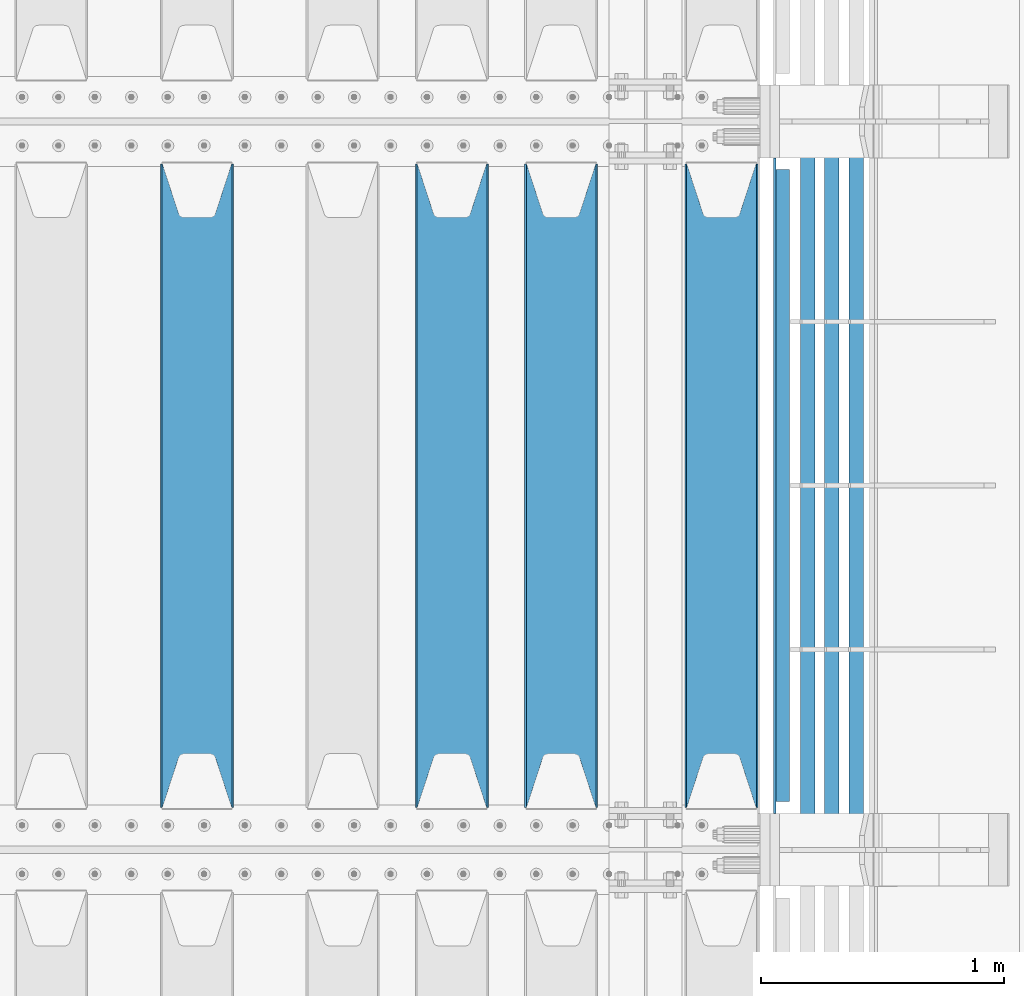
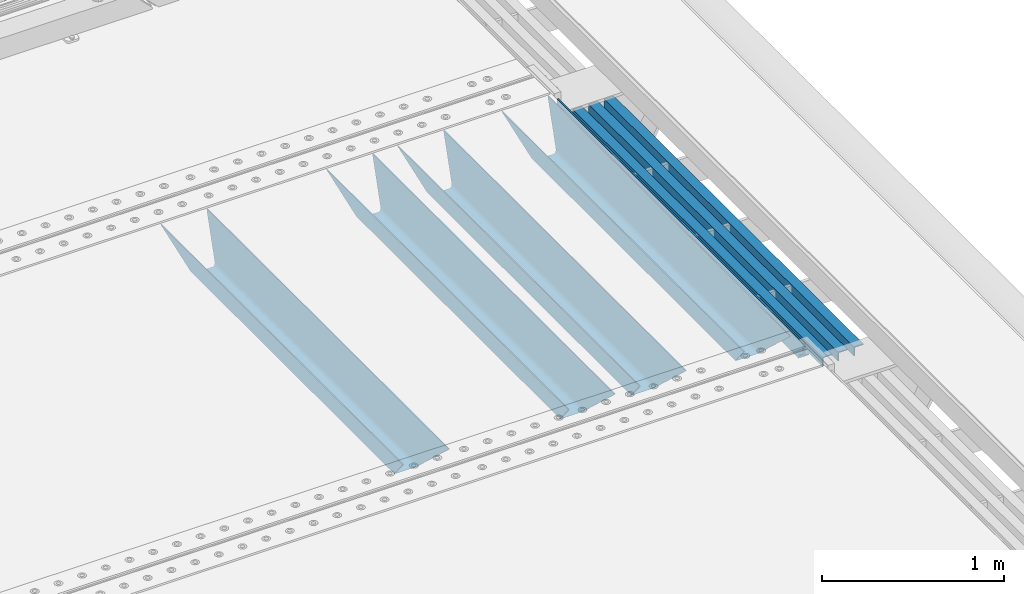
# One storey, part 143 of 270: 8 beams.
"""IFC2X3 building model written with IfcOpenShell, lengths in millimetres."""

import ifcopenshell
import ifcopenshell.guid

model = None  # the IFC model being written
_history = None  # IfcOwnerHistory: only IFC2X3 demands one
_inside = {}  # id of a spatial element -> (the spatial element, [elements in it])
_under = {}  # id of a project, library or spatial element -> (it, [spatial elements below it])
_declared = {}  # id of a project -> (the project, [libraries it declares])
_typed = {}  # id of a type object -> (the type object, [elements of that type])
_made_of = {}  # id of a material, layer set ... -> (it, [elements and type objects made of it])


def new_model(schema):
    """Start an empty IFC model of exactly this schema.

    Asked for "IFC4X3", IfcOpenShell would pick the latest addendum, in which some entities
    have other attributes; the version numbers below select the first issue.
    IFC2X3 requires an IfcOwnerHistory on every rooted entity: one is made here for all.
    """
    global model, _history
    if schema == "IFC4X3":
        model = ifcopenshell.file(schema_version=(4, 3, 0, 0))
    else:
        model = ifcopenshell.file(schema=schema)
    _inside.clear()
    _under.clear()
    _declared.clear()
    _typed.clear()
    _made_of.clear()
    _history = None
    if model.schema == "IFC2X3":
        org = make("IfcOrganization", Name="unknown")
        user = make(
            "IfcPersonAndOrganization",
            ThePerson=make("IfcPerson", FamilyName="unknown"),
            TheOrganization=org,
        )
        app = make(
            "IfcApplication",
            ApplicationDeveloper=org,
            Version="unknown",
            ApplicationFullName="unknown",
            ApplicationIdentifier="unknown",
        )
        _history = make(
            "IfcOwnerHistory",
            OwningUser=user,
            OwningApplication=app,
            ChangeAction="ADDED",
            CreationDate=0,
        )
    return model


def make(cls, **values):
    """One entity of the class cls with the attributes given. An attribute that is None is left unset."""
    return model.create_entity(
        cls, **{name: value for name, value in values.items() if value is not None}
    )


def rooted(cls, **values):
    """An entity with a GlobalId (a new one), such as an element, a storey or a relation."""
    return make(cls, GlobalId=ifcopenshell.guid.new(), OwnerHistory=_history, **values)


def si_unit(unit_type, name, prefix=None):
    """IfcSIUnit, for example si_unit("LENGTHUNIT", "METRE", prefix="MILLI")."""
    return make("IfcSIUnit", UnitType=unit_type, Prefix=prefix, Name=name)


def assignment(units):
    """IfcUnitAssignment: the units of a project."""
    return None if units is None else make("IfcUnitAssignment", Units=units)


def point(xyz):
    """IfcCartesianPoint."""
    return None if xyz is None else make("IfcCartesianPoint", Coordinates=xyz)


def direction(xyz):
    """IfcDirection."""
    return None if xyz is None else make("IfcDirection", DirectionRatios=xyz)


def frame(location, z_axis=None, x_axis=None):
    """IfcAxis2Placement3D, a coordinate frame: its origin and axes. An axis left out is left unset."""
    return make(
        "IfcAxis2Placement3D",
        Location=point(location),
        Axis=direction(z_axis),
        RefDirection=direction(x_axis),
    )


def origin_with_axes():
    """The frame at (0, 0, 0) with the z axis (0, 0, 1) and the x axis (1, 0, 0) written out."""
    return frame((0.0, 0.0, 0.0), z_axis=(0.0, 0.0, 1.0), x_axis=(1.0, 0.0, 0.0))


def place(relative_to, where):
    """IfcLocalPlacement: puts the frame where relative to a parent placement (None: the world)."""
    return make(
        "IfcLocalPlacement", PlacementRelTo=relative_to, RelativePlacement=where
    )


def context(
    kind, dimensions, precision=None, world=None, true_north=None, identifier=None
):
    """IfcGeometricRepresentationContext, for example the 3D "Model" context."""
    return make(
        "IfcGeometricRepresentationContext",
        ContextIdentifier=identifier,
        ContextType=kind,
        CoordinateSpaceDimension=dimensions,
        Precision=precision,
        WorldCoordinateSystem=world,
        TrueNorth=true_north,
    )


def subcontext(parent, identifier, kind, view, scale=None):
    """IfcGeometricRepresentationSubContext, for example "Body" below "Model"."""
    return make(
        "IfcGeometricRepresentationSubContext",
        ContextIdentifier=identifier,
        ContextType=kind,
        ParentContext=parent,
        TargetScale=scale,
        TargetView=view,
    )


def project(units=None, contexts=None):
    """IfcProject with its units and contexts."""
    return rooted(
        "IfcProject",
        Name="project",
        RepresentationContexts=contexts,
        UnitsInContext=assignment(units),
    )


def spatial(cls, under=None, at=None, **own):
    """A site, building, storey or space (cls), placed at a placement, below another one or the project."""
    s = rooted(cls, ObjectPlacement=at, **own)
    if under is not None:
        _under.setdefault(under.id(), (under, []))[1].append(s)
    return s


def faces_of(points, faces, orient=None, outer=None):
    """IfcFace entities. A face is a list of loops; a loop is a list of indices into points, from 0.

    orient and outer hold one flag for each loop. By default every Orientation is true, the
    first loop of a face is its IfcFaceOuterBound and the others are IfcFaceBound.
    """
    made = []
    for i, loops in enumerate(faces):
        bounds = []
        for j, loop in enumerate(loops):
            is_outer = j == 0 if outer is None else outer[i][j]
            bounds.append(
                make(
                    "IfcFaceOuterBound" if is_outer else "IfcFaceBound",
                    Bound=make("IfcPolyLoop", Polygon=[points[k] for k in loop]),
                    Orientation=True if orient is None else orient[i][j],
                )
            )
        made.append(make("IfcFace", Bounds=bounds))
    return made


def faceted_brep(points, faces, orient=None, outer=None, voids=None):
    """IfcFacetedBrep: a solid bounded by flat faces; with voids (closed shells), ...WithVoids."""
    shared = [point(p) for p in points]
    hull = make("IfcClosedShell", CfsFaces=faces_of(shared, faces, orient, outer))
    if voids is None:
        return make("IfcFacetedBrep", Outer=hull)
    return make(
        "IfcFacetedBrepWithVoids",
        Outer=hull,
        Voids=[
            make(cls, CfsFaces=faces_of(shared, fs, o, b)) for cls, fs, o, b in voids
        ],
    )


def shape(context_of_items, identifier, shape_type, items):
    """IfcShapeRepresentation: the items that make up one representation, for example the "Body"."""
    return make(
        "IfcShapeRepresentation",
        ContextOfItems=context_of_items,
        RepresentationIdentifier=identifier,
        RepresentationType=shape_type,
        Items=items,
    )


def material(Name=None, Category=None):
    """IfcMaterial."""
    return make("IfcMaterial", Name=Name, Category=Category)


def made_of(thing, what):
    """Note that an element or type object is made of a material, layer set ...; save() writes the relation."""
    if what is not None:
        _made_of.setdefault(what.id(), (what, []))[1].append(thing)
    return thing


def type_object(cls, material=None, **own):
    """A type object (cls), such as IfcWallType, which elements share."""
    return made_of(rooted(cls, **own), material)


def element(
    cls,
    number,
    at=None,
    inside=None,
    cuts=None,
    type_object=None,
    material=None,
    context=None,
    identifier="Body",
    shape_type=None,
    held_by="IfcProductDefinitionShape",
    body=None,
    shapes=None,
    **own,
):
    """One element of the class cls, such as IfcWall. Its Tag is "e" and its number.

    at: its placement. inside: the storey or other place that contains it. cuts: it is an
    opening in that element (IfcRelVoidsElement). A single representation is given by context,
    identifier, shape_type and body (its items); several are given by shapes. held_by: the class
    of the entity that holds the representations. save() writes the other relations.
    """
    e = rooted(cls, Tag="e%d" % number, ObjectPlacement=at, **own)
    if body is not None:
        shapes = [shape(context, identifier, shape_type, body)]
    if shapes is not None:
        e.Representation = make(held_by, Representations=shapes)
    if inside is not None:
        _inside.setdefault(inside.id(), (inside, []))[1].append(e)
    if cuts is not None:
        rooted(
            "IfcRelVoidsElement", RelatingBuildingElement=cuts, RelatedOpeningElement=e
        )
    if type_object is not None:
        _typed.setdefault(type_object.id(), (type_object, []))[1].append(e)
    return made_of(e, material)


def aggregate(whole, parts):
    """IfcRelAggregates: a whole, such as a stair, and the parts it consists of."""
    return rooted("IfcRelAggregates", RelatingObject=whole, RelatedObjects=parts)


def save(model, path):
    """Write the relations noted so far, then the file.

    IfcRelAggregates (storeys below a building ...), IfcRelContainedInSpatialStructure (elements
    in a storey), IfcRelDefinesByType, IfcRelAssociatesMaterial and IfcRelDeclares: one each for
    every whole, place, type object, material and project.
    """
    for whole, parts in _under.values():
        aggregate(whole, parts)
    for where, things in _inside.values():
        rooted(
            "IfcRelContainedInSpatialStructure",
            RelatedElements=things,
            RelatingStructure=where,
        )
    for kind, things in _typed.values():
        rooted("IfcRelDefinesByType", RelatedObjects=things, RelatingType=kind)
    for what, things in _made_of.values():
        rooted("IfcRelAssociatesMaterial", RelatedObjects=things, RelatingMaterial=what)
    for by, libraries in _declared.values():
        rooted("IfcRelDeclares", RelatingContext=by, RelatedDefinitions=libraries)
    model.write(path)


model = new_model("IFC2X3")

# Units and contexts
model_context = context("Model", 3, precision=1e-05, world=origin_with_axes())
body_context = subcontext(model_context, "Body", "Model", "MODEL_VIEW")
ifc_project = project(units=[si_unit("LENGTHUNIT", "METRE", prefix="MILLI"), si_unit("AREAUNIT", "SQUARE_METRE"), si_unit("VOLUMEUNIT", "CUBIC_METRE"), si_unit("MASSUNIT", "GRAM", prefix="KILO"), si_unit("TIMEUNIT", "SECOND"), si_unit("PLANEANGLEUNIT", "RADIAN"), si_unit("SOLIDANGLEUNIT", "STERADIAN"), si_unit("THERMODYNAMICTEMPERATUREUNIT", "DEGREE_CELSIUS"), si_unit("LUMINOUSINTENSITYUNIT", "LUMEN")], contexts=[model_context])

# Site, building, storey
site_placement = place(None, origin_with_axes())
site = spatial("IfcSite", under=ifc_project, at=site_placement, CompositionType="ELEMENT")
building_placement = place(site_placement, origin_with_axes())
building = spatial("IfcBuilding", under=site, at=building_placement, Name="Standard", CompositionType="ELEMENT")
storey_placement = place(building_placement, origin_with_axes())
storey = spatial("IfcBuildingStorey", under=building, at=storey_placement, Name="Undefined", CompositionType="ELEMENT", Elevation=0.0)

# Beams
ifc_material_1 = material(Name="STEEL/S355N")
beam_type_1 = type_object("IfcBeamType", PredefinedType="NOTDEFINED")
beam_1_placement = place(storey_placement, frame((20230.0, -20825.0, -115.0), z_axis=(0.0, 0.0, 1.0), x_axis=(0.0, 1.0, 0.0)))
element("IfcBeam", 1, at=beam_1_placement, inside=storey, type_object=beam_type_1, material=ifc_material_1, context=body_context, shape_type="Brep", body=[
    faceted_brep([(0.0, 150.0, 115.0), (0.0, 143.689999999999, 115.0), (2650.00000000297, 143.689999999999, 115.0), (2650.00000000297, 150.0, 115.0), (2650.00000000297, 142.059565218398, 110.000000003096), (2650.00000000297, 148.3695652184, 110.000000003096), (2441.90079219209, -80.1103600731112, -98.0992078077845), (2437.7588105432, -77.5672621345584, -102.241189456673), (2434.06523489747, -74.4080125315522, -105.934765102404), (2430.9108609509, -70.710272125576, -109.089139048974), (2428.37322971128, -66.5649389910068, -111.626770288588), (2426.51472138055, -62.0739139532889, -113.485278619323), (2425.38102192092, -57.3475956567672, -114.618978078955), (2424.99999999987, -52.5021667386536, -115.0), (2424.99999999987, 52.5021667386536, -115.0), (2425.38102192092, 57.3475956567672, -114.618978078955), (2426.51472138055, 62.0739139532889, -113.485278619323), (2428.37322971128, 66.5649389910068, -111.626770288588), (2430.9108609509, 70.710272125576, -109.089139048974), (2434.06523489747, 74.4080125315522, -105.934765102404), (2437.7588105432, 77.5672621345584, -102.241189456673), (2441.90079219209, 80.1103600731112, -98.0992078077846), (2446.38936140511, 81.9747917625791, -93.6106385947584), (2448.2494850041, 76.2713538057251, -91.7505149957729), (2444.62967112263, 74.76777986261, -95.3703288772456), (2441.28936334126, 72.7168944282894, -98.710636658607), (2438.31067330439, 70.1691124903846, -101.689326695487), (2435.76682334747, 67.1870637758839, -104.233176652398), (2433.72034654133, 63.8440531834895, -106.279653458539), (2432.22154950042, 60.222258798236, -107.778450499454), (2431.30727574265, 56.4107117849089, -108.692724257221), (2430.99999999987, 52.5031078186876, -109.0), (2430.99999999987, -52.5031078186876, -109.0), (2431.30727574265, -56.4107117849089, -108.692724257221), (2432.22154950042, -60.222258798236, -107.778450499454), (2433.72034654133, -63.8440531834895, -106.279653458539), (2435.76682334747, -67.1870637758839, -104.233176652398), (2438.31067330438, -70.1691124903846, -101.689326695487), (2441.28936334126, -72.7168944282894, -98.7106366586071), (2444.62967112263, -74.76777986261, -95.3703288772457), (2448.2494850041, -76.2713538057251, -91.7505149957729), (2650.00000000297, -142.059565218398, 110.000000003096), (2650.00000000297, -148.3695652184, 110.000000003096), (2446.38936140511, -81.9747917625791, -93.6106385947584), (2650.00000000297, -143.689999999999, 115.0), (2650.00000000297, -150.0, 115.0), (0.0, -143.689999999999, 115.0), (0.0, -150.0, 115.0), (0.0, -148.369565218261, 110.000000002672), (203.610638597431, -81.9747917625791, -93.6106385947584), (208.099207810457, -80.1103600731112, -98.0992078077845), (212.241189459342, -77.5672621345584, -102.241189456673), (215.934765105078, -74.4080125315522, -105.934765102404), (219.089139051644, -70.710272125576, -109.089139048974), (221.626770291259, -66.5649389910068, -111.626770288588), (223.485278621993, -62.0739139532889, -113.485278619323), (224.618978081628, -57.3475956567672, -114.618978078955), (225.00000000267, -52.5021667386536, -115.0), (225.00000000267, 52.5021667386536, -115.0), (224.618978081628, 57.3475956567672, -114.618978078955), (223.485278621993, 62.0739139532889, -113.485278619323), (221.626770291259, 66.5649389910068, -111.626770288588), (219.089139051644, 70.710272125576, -109.089139048974), (215.934765105078, 74.4080125315522, -105.934765102404), (212.241189459342, 77.5672621345584, -102.241189456673), (208.099207810457, 80.1103600731112, -98.0992078077846), (203.610638597431, 81.9747917625791, -93.6106385947584), (0.0, 148.369565218261, 110.000000002672), (0.0, 142.05956521826, 110.000000002672), (201.750514998446, 76.2713538057251, -91.7505149957729), (205.370328879915, 74.76777986261, -95.3703288772456), (208.710636661279, 72.7168944282894, -98.710636658607), (211.689326698157, 70.1691124903846, -101.689326695487), (214.233176655071, 67.1870637758839, -104.233176652398), (216.27965346121, 63.8440531834895, -106.279653458539), (217.778450502126, 60.222258798236, -107.778450499454), (218.692724259894, 56.4107117849089, -108.692724257221), (219.00000000267, 52.5031078186876, -109.0), (219.00000000267, -52.5031078186876, -109.0), (218.692724259894, -56.4107117849089, -108.692724257221), (217.778450502123, -60.222258798236, -107.778450499454), (216.27965346121, -63.8440531834895, -106.279653458539), (214.233176655071, -67.1870637758839, -104.233176652398), (211.689326698157, -70.1691124903846, -101.689326695487), (208.710636661279, -72.7168944282894, -98.7106366586071), (205.370328879915, -74.76777986261, -95.3703288772457), (201.750514998446, -76.2713538057251, -91.7505149957729), (0.0, -142.05956521826, 110.000000002672)], [[[0, 1, 2, 3]], [[3, 2, 4, 5]], [[6, 7, 8, 9, 10, 11, 12, 13, 14, 15, 16, 17, 18, 19, 20, 21, 22, 5, 4, 23, 24, 25, 26, 27, 28, 29, 30, 31, 32, 33, 34, 35, 36, 37, 38, 39, 40, 41, 42, 43]], [[44, 45, 42, 41]], [[46, 47, 45, 44]], [[43, 42, 45, 47, 48, 49]], [[6, 43, 49, 50]], [[7, 6, 50, 51]], [[8, 7, 51, 52]], [[9, 8, 52, 53]], [[10, 9, 53, 54]], [[11, 10, 54, 55]], [[12, 11, 55, 56]], [[13, 12, 56, 57]], [[14, 13, 57, 58]], [[15, 14, 58, 59]], [[16, 15, 59, 60]], [[17, 16, 60, 61]], [[18, 17, 61, 62]], [[19, 18, 62, 63]], [[20, 19, 63, 64]], [[21, 20, 64, 65]], [[22, 21, 65, 66]], [[0, 3, 5, 22, 66, 67]], [[1, 0, 67, 68]], [[23, 4, 2, 1, 68, 69]], [[24, 23, 69, 70]], [[25, 24, 70, 71]], [[26, 25, 71, 72]], [[27, 26, 72, 73]], [[28, 27, 73, 74]], [[29, 28, 74, 75]], [[30, 29, 75, 76]], [[31, 30, 76, 77]], [[32, 31, 77, 78]], [[33, 32, 78, 79]], [[34, 33, 79, 80]], [[35, 34, 80, 81]], [[36, 35, 81, 82]], [[37, 36, 82, 83]], [[38, 37, 83, 84]], [[39, 38, 84, 85]], [[40, 39, 85, 86]], [[46, 44, 41, 40, 86, 87]], [[47, 46, 87, 48]], [[86, 85, 84, 83, 82, 81, 80, 79, 78, 77, 76, 75, 74, 73, 72, 71, 70, 69, 68, 67, 66, 65, 64, 63, 62, 61, 60, 59, 58, 57, 56, 55, 54, 53, 52, 51, 50, 49, 48, 87]]]),
])
beam_2_placement = place(storey_placement, frame((19570.0, -20825.0, -115.0), z_axis=(0.0, 0.0, 1.0), x_axis=(0.0, 1.0, 0.0)))
element("IfcBeam", 2, at=beam_2_placement, inside=storey, type_object=beam_type_1, material=ifc_material_1, context=body_context, shape_type="Brep", body=[
    faceted_brep([(0.0, 150.0, 115.0), (0.0, 143.689999999999, 115.0), (2650.00000000297, 143.689999999999, 115.0), (2650.00000000297, 150.0, 115.0), (2650.00000000297, 142.059565218398, 110.000000003096), (2650.00000000297, 148.3695652184, 110.000000003096), (2441.90079219209, -80.1103600731112, -98.0992078077845), (2437.7588105432, -77.5672621345584, -102.241189456673), (2434.06523489747, -74.4080125315522, -105.934765102404), (2430.9108609509, -70.710272125576, -109.089139048974), (2428.37322971128, -66.5649389910068, -111.626770288588), (2426.51472138055, -62.0739139532889, -113.485278619323), (2425.38102192092, -57.3475956567672, -114.618978078955), (2424.99999999987, -52.5021667386536, -115.0), (2424.99999999987, 52.5021667386536, -115.0), (2425.38102192092, 57.3475956567672, -114.618978078955), (2426.51472138055, 62.0739139532889, -113.485278619323), (2428.37322971128, 66.5649389910068, -111.626770288588), (2430.9108609509, 70.710272125576, -109.089139048974), (2434.06523489747, 74.4080125315522, -105.934765102404), (2437.7588105432, 77.5672621345584, -102.241189456673), (2441.90079219209, 80.1103600731112, -98.0992078077846), (2446.38936140511, 81.9747917625791, -93.6106385947584), (2448.2494850041, 76.2713538057251, -91.7505149957729), (2444.62967112263, 74.76777986261, -95.3703288772456), (2441.28936334126, 72.7168944282894, -98.710636658607), (2438.31067330439, 70.1691124903846, -101.689326695487), (2435.76682334747, 67.1870637758839, -104.233176652398), (2433.72034654133, 63.8440531834895, -106.279653458539), (2432.22154950042, 60.222258798236, -107.778450499454), (2431.30727574265, 56.4107117849089, -108.692724257221), (2430.99999999987, 52.5031078186876, -109.0), (2430.99999999987, -52.5031078186876, -109.0), (2431.30727574265, -56.4107117849089, -108.692724257221), (2432.22154950042, -60.222258798236, -107.778450499454), (2433.72034654133, -63.8440531834895, -106.279653458539), (2435.76682334747, -67.1870637758839, -104.233176652398), (2438.31067330438, -70.1691124903846, -101.689326695487), (2441.28936334126, -72.7168944282894, -98.7106366586071), (2444.62967112263, -74.76777986261, -95.3703288772457), (2448.2494850041, -76.2713538057251, -91.7505149957729), (2650.00000000297, -142.059565218398, 110.000000003096), (2650.00000000297, -148.3695652184, 110.000000003096), (2446.38936140511, -81.9747917625791, -93.6106385947584), (2650.00000000297, -143.689999999999, 115.0), (2650.00000000297, -150.0, 115.0), (0.0, -143.689999999999, 115.0), (0.0, -150.0, 115.0), (0.0, -148.369565218261, 110.000000002672), (203.610638597431, -81.9747917625791, -93.6106385947584), (208.099207810457, -80.1103600731112, -98.0992078077845), (212.241189459342, -77.5672621345584, -102.241189456673), (215.934765105078, -74.4080125315522, -105.934765102404), (219.089139051644, -70.710272125576, -109.089139048974), (221.626770291259, -66.5649389910068, -111.626770288588), (223.485278621993, -62.0739139532889, -113.485278619323), (224.618978081628, -57.3475956567672, -114.618978078955), (225.00000000267, -52.5021667386536, -115.0), (225.00000000267, 52.5021667386536, -115.0), (224.618978081628, 57.3475956567672, -114.618978078955), (223.485278621993, 62.0739139532889, -113.485278619323), (221.626770291259, 66.5649389910068, -111.626770288588), (219.089139051644, 70.710272125576, -109.089139048974), (215.934765105078, 74.4080125315522, -105.934765102404), (212.241189459342, 77.5672621345584, -102.241189456673), (208.099207810457, 80.1103600731112, -98.0992078077846), (203.610638597431, 81.9747917625791, -93.6106385947584), (0.0, 148.369565218261, 110.000000002672), (0.0, 142.05956521826, 110.000000002672), (201.750514998446, 76.2713538057251, -91.7505149957729), (205.370328879915, 74.76777986261, -95.3703288772456), (208.710636661279, 72.7168944282894, -98.710636658607), (211.689326698157, 70.1691124903846, -101.689326695487), (214.233176655071, 67.1870637758839, -104.233176652398), (216.27965346121, 63.8440531834895, -106.279653458539), (217.778450502126, 60.222258798236, -107.778450499454), (218.692724259894, 56.4107117849089, -108.692724257221), (219.00000000267, 52.5031078186876, -109.0), (219.00000000267, -52.5031078186876, -109.0), (218.692724259894, -56.4107117849089, -108.692724257221), (217.778450502123, -60.222258798236, -107.778450499454), (216.27965346121, -63.8440531834895, -106.279653458539), (214.233176655071, -67.1870637758839, -104.233176652398), (211.689326698157, -70.1691124903846, -101.689326695487), (208.710636661279, -72.7168944282894, -98.7106366586071), (205.370328879915, -74.76777986261, -95.3703288772457), (201.750514998446, -76.2713538057251, -91.7505149957729), (0.0, -142.05956521826, 110.000000002672)], [[[0, 1, 2, 3]], [[3, 2, 4, 5]], [[6, 7, 8, 9, 10, 11, 12, 13, 14, 15, 16, 17, 18, 19, 20, 21, 22, 5, 4, 23, 24, 25, 26, 27, 28, 29, 30, 31, 32, 33, 34, 35, 36, 37, 38, 39, 40, 41, 42, 43]], [[44, 45, 42, 41]], [[46, 47, 45, 44]], [[43, 42, 45, 47, 48, 49]], [[6, 43, 49, 50]], [[7, 6, 50, 51]], [[8, 7, 51, 52]], [[9, 8, 52, 53]], [[10, 9, 53, 54]], [[11, 10, 54, 55]], [[12, 11, 55, 56]], [[13, 12, 56, 57]], [[14, 13, 57, 58]], [[15, 14, 58, 59]], [[16, 15, 59, 60]], [[17, 16, 60, 61]], [[18, 17, 61, 62]], [[19, 18, 62, 63]], [[20, 19, 63, 64]], [[21, 20, 64, 65]], [[22, 21, 65, 66]], [[0, 3, 5, 22, 66, 67]], [[1, 0, 67, 68]], [[23, 4, 2, 1, 68, 69]], [[24, 23, 69, 70]], [[25, 24, 70, 71]], [[26, 25, 71, 72]], [[27, 26, 72, 73]], [[28, 27, 73, 74]], [[29, 28, 74, 75]], [[30, 29, 75, 76]], [[31, 30, 76, 77]], [[32, 31, 77, 78]], [[33, 32, 78, 79]], [[34, 33, 79, 80]], [[35, 34, 80, 81]], [[36, 35, 81, 82]], [[37, 36, 82, 83]], [[38, 37, 83, 84]], [[39, 38, 84, 85]], [[40, 39, 85, 86]], [[46, 44, 41, 40, 86, 87]], [[47, 46, 87, 48]], [[86, 85, 84, 83, 82, 81, 80, 79, 78, 77, 76, 75, 74, 73, 72, 71, 70, 69, 68, 67, 66, 65, 64, 63, 62, 61, 60, 59, 58, 57, 56, 55, 54, 53, 52, 51, 50, 49, 48, 87]]]),
])
beam_3_placement = place(storey_placement, frame((19120.0, -20825.0, -115.0), z_axis=(0.0, 0.0, 1.0), x_axis=(0.0, 1.0, 0.0)))
element("IfcBeam", 3, at=beam_3_placement, inside=storey, type_object=beam_type_1, material=ifc_material_1, context=body_context, shape_type="Brep", body=[
    faceted_brep([(0.0, 150.0, 115.0), (0.0, 143.689999999999, 115.0), (2650.00000000297, 143.689999999999, 115.0), (2650.00000000297, 150.0, 115.0), (2650.00000000297, 142.059565218398, 110.000000003096), (2650.00000000297, 148.3695652184, 110.000000003096), (2441.90079219209, -80.1103600731112, -98.0992078077845), (2437.7588105432, -77.5672621345584, -102.241189456673), (2434.06523489747, -74.4080125315522, -105.934765102404), (2430.9108609509, -70.710272125576, -109.089139048974), (2428.37322971128, -66.5649389910068, -111.626770288588), (2426.51472138055, -62.0739139532889, -113.485278619323), (2425.38102192092, -57.3475956567672, -114.618978078955), (2424.99999999987, -52.5021667386536, -115.0), (2424.99999999987, 52.5021667386536, -115.0), (2425.38102192092, 57.3475956567672, -114.618978078955), (2426.51472138055, 62.0739139532889, -113.485278619323), (2428.37322971128, 66.5649389910068, -111.626770288588), (2430.9108609509, 70.710272125576, -109.089139048974), (2434.06523489747, 74.4080125315522, -105.934765102404), (2437.7588105432, 77.5672621345584, -102.241189456673), (2441.90079219209, 80.1103600731112, -98.0992078077846), (2446.38936140511, 81.9747917625791, -93.6106385947584), (2448.2494850041, 76.2713538057251, -91.7505149957729), (2444.62967112263, 74.76777986261, -95.3703288772456), (2441.28936334126, 72.7168944282894, -98.710636658607), (2438.31067330439, 70.1691124903846, -101.689326695487), (2435.76682334747, 67.1870637758839, -104.233176652398), (2433.72034654133, 63.8440531834895, -106.279653458539), (2432.22154950042, 60.222258798236, -107.778450499454), (2431.30727574265, 56.4107117849089, -108.692724257221), (2430.99999999987, 52.5031078186876, -109.0), (2430.99999999987, -52.5031078186876, -109.0), (2431.30727574265, -56.4107117849089, -108.692724257221), (2432.22154950042, -60.222258798236, -107.778450499454), (2433.72034654133, -63.8440531834895, -106.279653458539), (2435.76682334747, -67.1870637758839, -104.233176652398), (2438.31067330438, -70.1691124903846, -101.689326695487), (2441.28936334126, -72.7168944282894, -98.7106366586071), (2444.62967112263, -74.76777986261, -95.3703288772457), (2448.2494850041, -76.2713538057251, -91.7505149957729), (2650.00000000297, -142.059565218398, 110.000000003096), (2650.00000000297, -148.3695652184, 110.000000003096), (2446.38936140511, -81.9747917625791, -93.6106385947584), (2650.00000000297, -143.689999999999, 115.0), (2650.00000000297, -150.0, 115.0), (0.0, -143.689999999999, 115.0), (0.0, -150.0, 115.0), (0.0, -148.369565218261, 110.000000002672), (203.610638597431, -81.9747917625791, -93.6106385947584), (208.099207810457, -80.1103600731112, -98.0992078077845), (212.241189459342, -77.5672621345584, -102.241189456673), (215.934765105078, -74.4080125315522, -105.934765102404), (219.089139051644, -70.710272125576, -109.089139048974), (221.626770291259, -66.5649389910068, -111.626770288588), (223.485278621993, -62.0739139532889, -113.485278619323), (224.618978081628, -57.3475956567672, -114.618978078955), (225.00000000267, -52.5021667386536, -115.0), (225.00000000267, 52.5021667386536, -115.0), (224.618978081628, 57.3475956567672, -114.618978078955), (223.485278621993, 62.0739139532889, -113.485278619323), (221.626770291259, 66.5649389910068, -111.626770288588), (219.089139051644, 70.710272125576, -109.089139048974), (215.934765105078, 74.4080125315522, -105.934765102404), (212.241189459342, 77.5672621345584, -102.241189456673), (208.099207810457, 80.1103600731112, -98.0992078077846), (203.610638597431, 81.9747917625791, -93.6106385947584), (0.0, 148.369565218261, 110.000000002672), (0.0, 142.05956521826, 110.000000002672), (201.750514998446, 76.2713538057251, -91.7505149957729), (205.370328879915, 74.76777986261, -95.3703288772456), (208.710636661279, 72.7168944282894, -98.710636658607), (211.689326698157, 70.1691124903846, -101.689326695487), (214.233176655071, 67.1870637758839, -104.233176652398), (216.27965346121, 63.8440531834895, -106.279653458539), (217.778450502126, 60.222258798236, -107.778450499454), (218.692724259894, 56.4107117849089, -108.692724257221), (219.00000000267, 52.5031078186876, -109.0), (219.00000000267, -52.5031078186876, -109.0), (218.692724259894, -56.4107117849089, -108.692724257221), (217.778450502123, -60.222258798236, -107.778450499454), (216.27965346121, -63.8440531834895, -106.279653458539), (214.233176655071, -67.1870637758839, -104.233176652398), (211.689326698157, -70.1691124903846, -101.689326695487), (208.710636661279, -72.7168944282894, -98.7106366586071), (205.370328879915, -74.76777986261, -95.3703288772457), (201.750514998446, -76.2713538057251, -91.7505149957729), (0.0, -142.05956521826, 110.000000002672)], [[[0, 1, 2, 3]], [[3, 2, 4, 5]], [[6, 7, 8, 9, 10, 11, 12, 13, 14, 15, 16, 17, 18, 19, 20, 21, 22, 5, 4, 23, 24, 25, 26, 27, 28, 29, 30, 31, 32, 33, 34, 35, 36, 37, 38, 39, 40, 41, 42, 43]], [[44, 45, 42, 41]], [[46, 47, 45, 44]], [[43, 42, 45, 47, 48, 49]], [[6, 43, 49, 50]], [[7, 6, 50, 51]], [[8, 7, 51, 52]], [[9, 8, 52, 53]], [[10, 9, 53, 54]], [[11, 10, 54, 55]], [[12, 11, 55, 56]], [[13, 12, 56, 57]], [[14, 13, 57, 58]], [[15, 14, 58, 59]], [[16, 15, 59, 60]], [[17, 16, 60, 61]], [[18, 17, 61, 62]], [[19, 18, 62, 63]], [[20, 19, 63, 64]], [[21, 20, 64, 65]], [[22, 21, 65, 66]], [[0, 3, 5, 22, 66, 67]], [[1, 0, 67, 68]], [[23, 4, 2, 1, 68, 69]], [[24, 23, 69, 70]], [[25, 24, 70, 71]], [[26, 25, 71, 72]], [[27, 26, 72, 73]], [[28, 27, 73, 74]], [[29, 28, 74, 75]], [[30, 29, 75, 76]], [[31, 30, 76, 77]], [[32, 31, 77, 78]], [[33, 32, 78, 79]], [[34, 33, 79, 80]], [[35, 34, 80, 81]], [[36, 35, 81, 82]], [[37, 36, 82, 83]], [[38, 37, 83, 84]], [[39, 38, 84, 85]], [[40, 39, 85, 86]], [[46, 44, 41, 40, 86, 87]], [[47, 46, 87, 48]], [[86, 85, 84, 83, 82, 81, 80, 79, 78, 77, 76, 75, 74, 73, 72, 71, 70, 69, 68, 67, 66, 65, 64, 63, 62, 61, 60, 59, 58, 57, 56, 55, 54, 53, 52, 51, 50, 49, 48, 87]]]),
])
beam_4_placement = place(storey_placement, frame((18070.0, -20825.0, -115.0), z_axis=(0.0, 0.0, 1.0), x_axis=(0.0, 1.0, 0.0)))
element("IfcBeam", 4, at=beam_4_placement, inside=storey, type_object=beam_type_1, material=ifc_material_1, context=body_context, shape_type="Brep", body=[
    faceted_brep([(0.0, 150.0, 115.0), (0.0, 143.689999999999, 115.0), (2650.00000000297, 143.689999999999, 115.0), (2650.00000000297, 150.0, 115.0), (2650.00000000297, 142.059565218398, 110.000000003096), (2650.00000000297, 148.3695652184, 110.000000003096), (2441.90079219209, -80.1103600731112, -98.0992078077845), (2437.7588105432, -77.5672621345584, -102.241189456673), (2434.06523489747, -74.4080125315522, -105.934765102404), (2430.9108609509, -70.710272125576, -109.089139048974), (2428.37322971128, -66.5649389910068, -111.626770288588), (2426.51472138055, -62.0739139532889, -113.485278619323), (2425.38102192092, -57.3475956567672, -114.618978078955), (2424.99999999987, -52.5021667386536, -115.0), (2424.99999999987, 52.5021667386536, -115.0), (2425.38102192092, 57.3475956567672, -114.618978078955), (2426.51472138055, 62.0739139532889, -113.485278619323), (2428.37322971128, 66.5649389910068, -111.626770288588), (2430.9108609509, 70.710272125576, -109.089139048974), (2434.06523489747, 74.4080125315522, -105.934765102404), (2437.7588105432, 77.5672621345584, -102.241189456673), (2441.90079219209, 80.1103600731112, -98.0992078077846), (2446.38936140511, 81.9747917625791, -93.6106385947584), (2448.2494850041, 76.2713538057251, -91.7505149957729), (2444.62967112263, 74.76777986261, -95.3703288772456), (2441.28936334126, 72.7168944282894, -98.710636658607), (2438.31067330439, 70.1691124903846, -101.689326695487), (2435.76682334747, 67.1870637758839, -104.233176652398), (2433.72034654133, 63.8440531834895, -106.279653458539), (2432.22154950042, 60.222258798236, -107.778450499454), (2431.30727574265, 56.4107117849089, -108.692724257221), (2430.99999999987, 52.5031078186876, -109.0), (2430.99999999987, -52.5031078186876, -109.0), (2431.30727574265, -56.4107117849089, -108.692724257221), (2432.22154950042, -60.222258798236, -107.778450499454), (2433.72034654133, -63.8440531834895, -106.279653458539), (2435.76682334747, -67.1870637758839, -104.233176652398), (2438.31067330438, -70.1691124903846, -101.689326695487), (2441.28936334126, -72.7168944282894, -98.7106366586071), (2444.62967112263, -74.76777986261, -95.3703288772457), (2448.2494850041, -76.2713538057251, -91.7505149957729), (2650.00000000297, -142.059565218398, 110.000000003096), (2650.00000000297, -148.3695652184, 110.000000003096), (2446.38936140511, -81.9747917625791, -93.6106385947584), (2650.00000000297, -143.689999999999, 115.0), (2650.00000000297, -150.0, 115.0), (0.0, -143.689999999999, 115.0), (0.0, -150.0, 115.0), (0.0, -148.369565218261, 110.000000002672), (203.610638597431, -81.9747917625791, -93.6106385947584), (208.099207810457, -80.1103600731112, -98.0992078077845), (212.241189459342, -77.5672621345584, -102.241189456673), (215.934765105078, -74.4080125315522, -105.934765102404), (219.089139051644, -70.710272125576, -109.089139048974), (221.626770291259, -66.5649389910068, -111.626770288588), (223.485278621993, -62.0739139532889, -113.485278619323), (224.618978081628, -57.3475956567672, -114.618978078955), (225.00000000267, -52.5021667386536, -115.0), (225.00000000267, 52.5021667386536, -115.0), (224.618978081628, 57.3475956567672, -114.618978078955), (223.485278621993, 62.0739139532889, -113.485278619323), (221.626770291259, 66.5649389910068, -111.626770288588), (219.089139051644, 70.710272125576, -109.089139048974), (215.934765105078, 74.4080125315522, -105.934765102404), (212.241189459342, 77.5672621345584, -102.241189456673), (208.099207810457, 80.1103600731112, -98.0992078077846), (203.610638597431, 81.9747917625791, -93.6106385947584), (0.0, 148.369565218261, 110.000000002672), (0.0, 142.05956521826, 110.000000002672), (201.750514998446, 76.2713538057251, -91.7505149957729), (205.370328879915, 74.76777986261, -95.3703288772456), (208.710636661279, 72.7168944282894, -98.710636658607), (211.689326698157, 70.1691124903846, -101.689326695487), (214.233176655071, 67.1870637758839, -104.233176652398), (216.27965346121, 63.8440531834895, -106.279653458539), (217.778450502126, 60.222258798236, -107.778450499454), (218.692724259894, 56.4107117849089, -108.692724257221), (219.00000000267, 52.5031078186876, -109.0), (219.00000000267, -52.5031078186876, -109.0), (218.692724259894, -56.4107117849089, -108.692724257221), (217.778450502123, -60.222258798236, -107.778450499454), (216.27965346121, -63.8440531834895, -106.279653458539), (214.233176655071, -67.1870637758839, -104.233176652398), (211.689326698157, -70.1691124903846, -101.689326695487), (208.710636661279, -72.7168944282894, -98.7106366586071), (205.370328879915, -74.76777986261, -95.3703288772457), (201.750514998446, -76.2713538057251, -91.7505149957729), (0.0, -142.05956521826, 110.000000002672)], [[[0, 1, 2, 3]], [[3, 2, 4, 5]], [[6, 7, 8, 9, 10, 11, 12, 13, 14, 15, 16, 17, 18, 19, 20, 21, 22, 5, 4, 23, 24, 25, 26, 27, 28, 29, 30, 31, 32, 33, 34, 35, 36, 37, 38, 39, 40, 41, 42, 43]], [[44, 45, 42, 41]], [[46, 47, 45, 44]], [[43, 42, 45, 47, 48, 49]], [[6, 43, 49, 50]], [[7, 6, 50, 51]], [[8, 7, 51, 52]], [[9, 8, 52, 53]], [[10, 9, 53, 54]], [[11, 10, 54, 55]], [[12, 11, 55, 56]], [[13, 12, 56, 57]], [[14, 13, 57, 58]], [[15, 14, 58, 59]], [[16, 15, 59, 60]], [[17, 16, 60, 61]], [[18, 17, 61, 62]], [[19, 18, 62, 63]], [[20, 19, 63, 64]], [[21, 20, 64, 65]], [[22, 21, 65, 66]], [[0, 3, 5, 22, 66, 67]], [[1, 0, 67, 68]], [[23, 4, 2, 1, 68, 69]], [[24, 23, 69, 70]], [[25, 24, 70, 71]], [[26, 25, 71, 72]], [[27, 26, 72, 73]], [[28, 27, 73, 74]], [[29, 28, 74, 75]], [[30, 29, 75, 76]], [[31, 30, 76, 77]], [[32, 31, 77, 78]], [[33, 32, 78, 79]], [[34, 33, 79, 80]], [[35, 34, 80, 81]], [[36, 35, 81, 82]], [[37, 36, 82, 83]], [[38, 37, 83, 84]], [[39, 38, 84, 85]], [[40, 39, 85, 86]], [[46, 44, 41, 40, 86, 87]], [[47, 46, 87, 48]], [[86, 85, 84, 83, 82, 81, 80, 79, 78, 77, 76, 75, 74, 73, 72, 71, 70, 69, 68, 67, 66, 65, 64, 63, 62, 61, 60, 59, 58, 57, 56, 55, 54, 53, 52, 51, 50, 49, 48, 87]]]),
])
ifc_material_2 = material(Name="STEEL/S355J2")
beam_type_2 = type_object("IfcBeamType", PredefinedType="NOTDEFINED")
beam_5_placement = place(storey_placement, frame((20477.5025260065, -20850.0, -124.999999999985), z_axis=(0.0, 0.0, 1.0), x_axis=(0.0, 1.0, 0.0)))
element("IfcBeam", 5, at=beam_5_placement, inside=storey, type_object=beam_type_2, material=ifc_material_2, context=body_context, shape_type="Brep", body=[
    faceted_brep([(2700.0, 22.5, -15.0), (2684.54915028125, 22.5, -17.4471741852423), (2684.54915028125, 32.5, -17.4471741852423), (2700.0, 32.5, -15.0), (2670.61073738538, 22.5, -24.5491502812526), (2670.61073738538, 32.5, -24.5491502812526), (2659.54915028125, 22.5, -35.6107373853764), (2659.54915028125, 32.5, -35.6107373853764), (2652.44717418524, 22.5, -49.5491502812526), (2652.44717418524, 32.5, -49.5491502812526), (2651.58384440325, -32.5, -55.0), (2650.0, -32.5, -65.0), (2650.0, 32.5, -65.0), (2651.58384440325, 22.5, -55.0), (0.0, 32.5, 65.0), (0.0, 22.5, 65.0), (2700.0, 22.5, 65.0), (2700.0, 32.5, 65.0), (0.0, 32.5, -15.0), (0.0, 22.5, -15.0), (15.4508497187489, 32.5, -17.4471741852423), (15.4508497187489, 22.5, -17.4471741852423), (29.3892626146226, 32.5, -24.5491502812526), (29.3892626146226, 22.5, -24.5491502812526), (40.4508497187489, 32.5, -35.6107373853763), (40.4508497187489, 22.5, -35.6107373853763), (47.5528258147569, 32.5, -49.5491502812526), (47.5528258147569, 22.5, -49.5491502812526), (50.0, -32.5, -65.0), (48.4161555967512, -32.5, -55.0), (48.4161555967512, 22.5, -55.0), (50.0, 32.5, -65.0)], [[[0, 1, 2, 3]], [[4, 5, 2, 1]], [[6, 7, 5, 4]], [[8, 9, 7, 6]], [[10, 11, 12, 9, 8, 13]], [[14, 15, 16, 17]], [[15, 14, 18, 19]], [[19, 18, 20, 21]], [[21, 20, 22, 23]], [[23, 22, 24, 25]], [[25, 24, 26, 27]], [[28, 29, 30, 27, 26, 31]], [[30, 29, 10, 13]], [[16, 15, 19, 21, 23, 25, 27, 30, 13, 8, 6, 4, 1, 0]], [[17, 16, 0, 3]], [[5, 7, 9, 12, 31, 26, 24, 22, 20, 18, 14, 17, 3, 2]], [[28, 31, 12, 11]], [[29, 28, 11, 10]]]),
])
beam_type_3 = type_object("IfcBeamType", PredefinedType="NOTDEFINED")
for number, where, z_axis, x_axis in (
    (6, (20785.0025260169, -18130.0000996114, -209.999999999563), (0.0, 0.0, -1.0), (0.0, -1.0, 0.0)),
    (7, (20685.0025260169, -18130.0000996114, -209.999999999563), (0.0, 0.0, -1.0), (0.0, -1.0, 0.0)),
    (8, (20585.0025260162, -18129.9999976868, -209.999999999622), (0.0, 0.0, -1.0), (0.0, -1.0, 0.0)),
):
    element("IfcBeam", number, at=place(storey_placement, frame(where, z_axis=z_axis, x_axis=x_axis)), inside=storey, type_object=beam_type_3, material=ifc_material_2, context=body_context, shape_type="Brep", body=[
        faceted_brep([(3.63797880709171e-12, 29.9999999999927, -30.0), (0.0, 29.9999999999927, 30.0000000000001), (2740.00017042501, 29.9999999999927, 30.0000000000001), (2740.00017042501, 29.9999999999927, -29.9999999999999), (0.0, 23.9999999999927, 30.0), (2740.00017042501, 23.9999999999927, 30.0), (0.0, 23.9999999999927, -24.0), (2740.00017042502, 23.9999999999927, -24.0), (0.0, -30.0000000000073, -24.0), (2740.00017042502, -30.0000000000073, -24.0), (0.0, -30.0000000000073, -30.0), (2740.00017042502, -30.0000000000073, -30.0)], [[[0, 1, 2, 3]], [[1, 4, 5, 2]], [[4, 6, 7, 5]], [[6, 8, 9, 7]], [[8, 10, 11, 9]], [[10, 0, 3, 11]], [[5, 7, 9, 11, 3, 2]], [[10, 8, 6, 4, 1, 0]]]),
    ])

save(model, "model.ifc")
